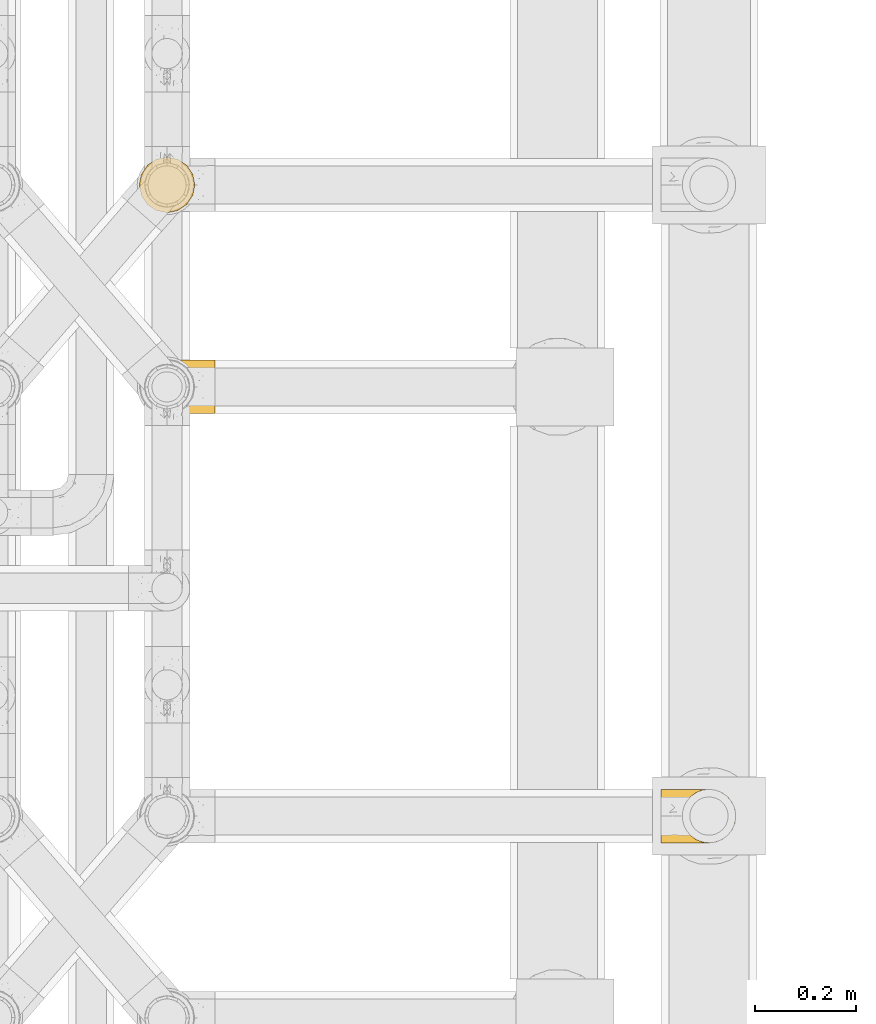
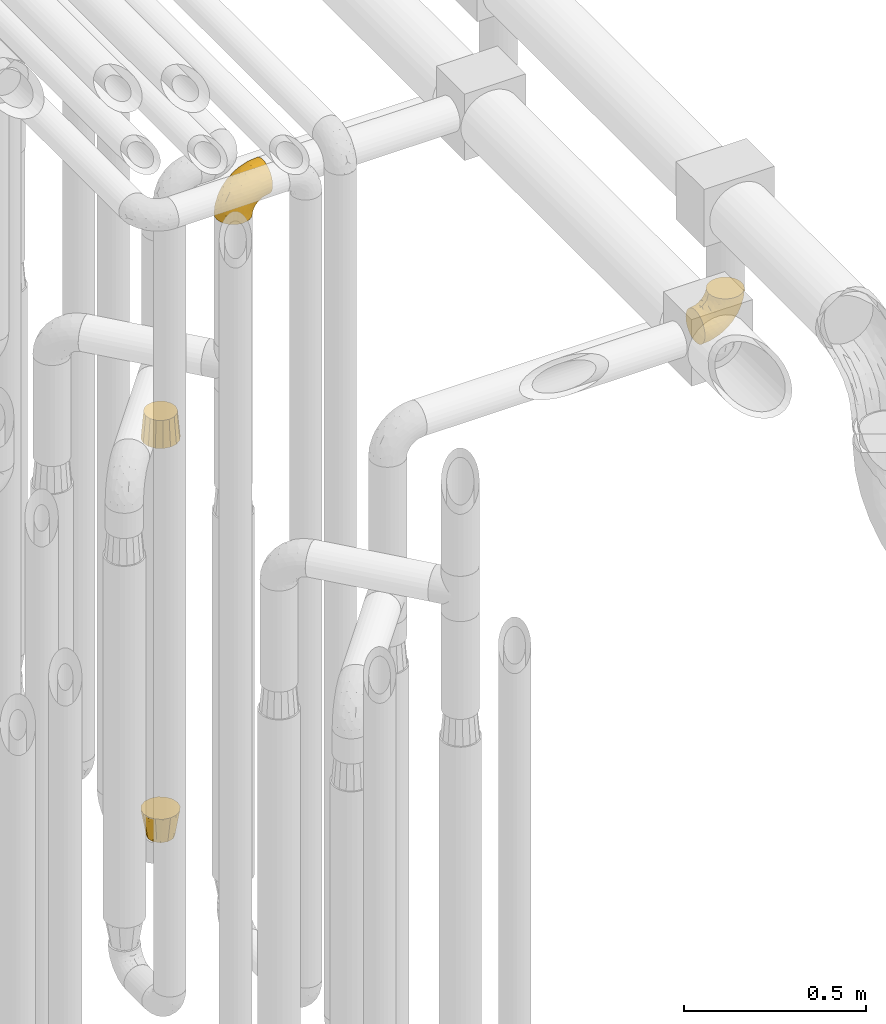
# One storey, part 220 of 827: 4 coverings.
"""IFC2X3 building model written with IfcOpenShell, lengths in millimetres."""

from ifc_helpers import new_model, entity, si_unit, converted_unit, derived_unit, direction, frame, origin, place, context, subcontext, project, spatial, faceted_brep, element, save


model = new_model("IFC2X3")

# Units and contexts
model_context = context("Model", 3, precision=0.01, world=origin(), true_north=direction((6.12303176911189e-17, 1.0)))
body_context = subcontext(model_context, "Body", "Model", "MODEL_VIEW")
ifc_project = project(units=[si_unit("LENGTHUNIT", "METRE", prefix="MILLI"), si_unit("AREAUNIT", "SQUARE_METRE"), si_unit("VOLUMEUNIT", "CUBIC_METRE"), converted_unit("PLANEANGLEUNIT", "DEGREE", entity("IfcRatioMeasure", 0.0174532925199433), si_unit("PLANEANGLEUNIT", "RADIAN"), dimensions=[0, 0, 0, 0, 0, 0, 0]), si_unit("MASSUNIT", "GRAM", prefix="KILO"), derived_unit("MASSDENSITYUNIT", [(si_unit("MASSUNIT", "GRAM", prefix="KILO"), 1), (si_unit("LENGTHUNIT", "METRE"), -3)]), derived_unit("MOMENTOFINERTIAUNIT", [(si_unit("LENGTHUNIT", "METRE"), 4)]), si_unit("TIMEUNIT", "SECOND"), si_unit("FREQUENCYUNIT", "HERTZ"), si_unit("THERMODYNAMICTEMPERATUREUNIT", "DEGREE_CELSIUS"), derived_unit("THERMALTRANSMITTANCEUNIT", [(si_unit("MASSUNIT", "GRAM", prefix="KILO"), 1), (si_unit("THERMODYNAMICTEMPERATUREUNIT", "KELVIN"), -1), (si_unit("TIMEUNIT", "SECOND"), -3)]), derived_unit("VOLUMETRICFLOWRATEUNIT", [(si_unit("LENGTHUNIT", "METRE"), 3), (si_unit("TIMEUNIT", "SECOND"), -1)]), derived_unit("MASSFLOWRATEUNIT", [(si_unit("MASSUNIT", "GRAM", prefix="KILO"), 1), (si_unit("TIMEUNIT", "SECOND"), -1)]), derived_unit("ROTATIONALFREQUENCYUNIT", [(si_unit("TIMEUNIT", "SECOND"), -1)]), si_unit("ELECTRICCURRENTUNIT", "AMPERE"), si_unit("ELECTRICVOLTAGEUNIT", "VOLT"), si_unit("POWERUNIT", "WATT"), si_unit("FORCEUNIT", "NEWTON", prefix="KILO"), si_unit("ILLUMINANCEUNIT", "LUX"), si_unit("LUMINOUSFLUXUNIT", "LUMEN"), si_unit("LUMINOUSINTENSITYUNIT", "CANDELA"), derived_unit("USERDEFINED", [(si_unit("MASSUNIT", "GRAM", prefix="KILO"), -1), (si_unit("LENGTHUNIT", "METRE"), -2), (si_unit("TIMEUNIT", "SECOND"), 3), (si_unit("LUMINOUSFLUXUNIT", "LUMEN"), 1)]), derived_unit("LINEARVELOCITYUNIT", [(si_unit("LENGTHUNIT", "METRE"), 1), (si_unit("TIMEUNIT", "SECOND"), -1)]), si_unit("PRESSUREUNIT", "PASCAL"), derived_unit("USERDEFINED", [(si_unit("LENGTHUNIT", "METRE"), -2), (si_unit("MASSUNIT", "GRAM", prefix="KILO"), 1), (si_unit("TIMEUNIT", "SECOND"), -2)]), derived_unit("LINEARFORCEUNIT", [(si_unit("MASSUNIT", "GRAM", prefix="KILO"), 1), (si_unit("LENGTHUNIT", "METRE"), 1), (si_unit("TIMEUNIT", "SECOND"), -2), (si_unit("LENGTHUNIT", "METRE"), -1)]), derived_unit("PLANARFORCEUNIT", [(si_unit("MASSUNIT", "GRAM", prefix="KILO"), 1), (si_unit("LENGTHUNIT", "METRE"), 1), (si_unit("TIMEUNIT", "SECOND"), -2), (si_unit("LENGTHUNIT", "METRE"), -2)])], contexts=[model_context])

# Site, building, storey
site_placement = place(None, origin())
site = spatial("IfcSite", under=ifc_project, at=site_placement, CompositionType="ELEMENT")
building_placement = place(site_placement, origin())
building = spatial("IfcBuilding", under=site, at=building_placement, CompositionType="ELEMENT")
storey_placement = place(building_placement, frame((0.0, 0.0, 28200.0)))
storey = spatial("IfcBuildingStorey", under=building, at=storey_placement, Name="08", CompositionType="ELEMENT", Elevation=28200.0)

# Coverings
covering_1_placement = place(storey_placement, frame((37951.7, 10425.56, 2545.35)))
element("IfcCovering", 1, at=covering_1_placement, inside=storey, Name=":ADSK_", ObjectType=":ADSK_", PredefinedType="INSULATION", context=body_context, shape_type="Brep", body=[
    faceted_brep([(1.6, 66.44, 2.92), (1.6, 54.65, 1.6), (1.6, 42.84, 2.93), (1.6, 31.62, 6.85), (1.6, 21.56, 13.18), (1.6, 13.16, 21.58), (1.6, 6.84, 31.64), (1.6, 2.92, 42.85), (1.6, 1.6, 54.65), (1.6, 2.93, 66.46), (1.6, 6.85, 77.67), (1.6, 13.18, 87.73), (1.6, 21.58, 96.13), (1.6, 31.64, 102.45), (1.6, 42.85, 106.37), (1.6, 54.65, 107.7), (1.6, 66.46, 106.36), (1.6, 77.67, 102.44), (1.6, 87.73, 96.11), (1.6, 96.13, 87.71), (1.6, 102.45, 77.65), (1.6, 106.37, 66.44), (1.6, 107.7, 54.65), (1.6, 106.36, 42.84), (1.6, 102.44, 31.62), (1.6, 96.11, 21.56), (1.6, 87.71, 13.16), (1.6, 77.65, 6.84), (45.35, 40.91, 149.65), (50.65, 28.12, 149.65), (59.08, 17.13, 149.65), (70.07, 8.7, 149.65), (82.86, 3.4, 149.65), (96.6, 1.6, 149.65), (110.33, 3.4, 149.65), (123.12, 8.7, 149.65), (134.11, 17.13, 149.65), (142.54, 28.12, 149.65), (147.84, 40.91, 149.65), (149.65, 54.65, 149.65), (147.84, 68.38, 149.65), (142.54, 81.17, 149.65), (134.11, 92.16, 149.65), (123.12, 100.59, 149.65), (110.33, 105.89, 149.65), (96.6, 107.7, 149.65), (82.86, 105.89, 149.65), (70.07, 100.59, 149.65), (59.08, 92.16, 149.65), (50.65, 81.17, 149.65), (45.35, 68.38, 149.65), (43.55, 54.65, 149.65), (137.19, 85.53, 123.27), (141.79, 73.42, 114.15), (128.89, 83.77, 92.97), (146.54, 64.22, 124.11), (144.6, 54.65, 111.33), (69.77, 96.72, 42.13), (94.41, 93.36, 56.83), (87.22, 84.47, 40.31), (117.2, 71.37, 61.55), (129.81, 54.65, 75.62), (106.28, 54.65, 44.96), (101.45, 103.47, 91.12), (115.81, 100.91, 109.83), (109.14, 99.1, 88.02), (107.65, 105.43, 119.19), (93.36, 106.79, 99.11), (59.44, 89.81, 27.97), (63.23, 79.59, 21.92), (35.59, 81.29, 12.94), (132.3, 74.01, 88.29), (138.41, 64.14, 95.35), (126.28, 94.75, 113.84), (39.91, 54.65, 6.64), (37.44, 70.74, 8.58), (90.35, 68.3, 33.39), (65.0, 66.05, 17.23), (85.4, 100.73, 61.99), (26.66, 106.78, 47.9), (29.88, 103.6, 37.72), (78.45, 107.7, 93.81), (85.2, 107.7, 107.05), (91.95, 107.7, 120.29), (77.98, 106.07, 73.26), (29.55, 90.59, 18.58), (41.42, 97.43, 29.72), (111.13, 84.51, 64.31), (114.67, 93.3, 82.84), (57.43, 107.7, 72.79), (67.94, 107.7, 83.3), (14.64, 107.7, 56.71), (30.95, 107.7, 59.29), (52.13, 106.79, 57.88), (44.19, 107.7, 66.04), (60.12, 103.47, 49.8), (75.62, 54.65, 21.43), (94.27, 107.7, 134.97), (24.59, 76.99, 108.79), (34.69, 84.28, 110.84), (31.15, 91.11, 101.53), (75.18, 106.26, 111.84), (67.55, 102.6, 119.98), (79.36, 106.08, 123.54), (84.32, 106.56, 134.54), (40.81, 105.36, 80.57), (29.93, 106.74, 69.55), (70.24, 101.59, 134.56), (37.93, 54.65, 128.67), (40.15, 54.65, 136.98), (42.1, 67.71, 133.56), (55.38, 91.36, 131.66), (52.17, 94.33, 117.75), (44.32, 87.1, 118.23), (19.85, 65.84, 110.55), (14.26, 54.65, 111.09), (22.57, 54.65, 113.32), (34.17, 68.92, 120.2), (54.85, 100.82, 105.95), (44.63, 79.83, 127.69), (47.52, 77.13, 139.88), (59.1, 105.9, 92.14), (44.11, 101.53, 93.82), (53.21, 106.72, 82.28), (62.86, 97.75, 130.86), (20.58, 103.08, 78.78), (15.79, 106.39, 67.58), (27.67, 98.1, 90.58), (13.49, 95.02, 90.23), (18.04, 86.9, 99.39), (12.44, 74.42, 105.17), (30.25, 54.65, 120.99), (66.71, 105.28, 104.59), (42.52, 92.87, 108.24), (55.38, 17.93, 131.66), (20.57, 6.22, 78.8), (42.11, 41.58, 133.57), (57.43, 1.6, 72.79), (53.22, 2.57, 82.27), (40.81, 3.94, 80.59), (19.85, 43.46, 110.55), (24.58, 32.32, 108.79), (34.16, 40.38, 120.2), (42.5, 16.44, 108.25), (54.93, 8.47, 106.06), (52.13, 15.01, 117.78), (27.66, 11.21, 90.6), (44.12, 7.78, 93.87), (78.45, 1.6, 93.81), (85.2, 1.6, 107.05), (75.17, 3.04, 111.89), (94.27, 1.6, 134.97), (84.32, 2.73, 134.54), (30.95, 1.6, 59.29), (44.19, 1.6, 66.04), (29.98, 2.55, 69.56), (66.78, 3.98, 104.56), (67.55, 6.69, 119.98), (70.24, 7.7, 134.56), (79.36, 3.21, 123.54), (13.48, 14.28, 90.25), (18.03, 22.42, 99.4), (34.66, 25.02, 110.83), (31.14, 18.18, 101.52), (12.43, 34.89, 105.18), (14.64, 1.6, 56.71), (47.52, 32.17, 139.89), (44.28, 22.23, 118.22), (15.8, 2.91, 67.6), (62.86, 11.54, 130.86), (67.94, 1.6, 83.3), (59.12, 3.38, 92.12), (44.64, 29.46, 127.71), (91.95, 1.6, 120.29), (128.89, 25.52, 92.97), (137.19, 23.76, 123.27), (126.28, 14.54, 113.84), (115.81, 8.38, 109.83), (146.53, 45.07, 124.03), (141.79, 35.87, 114.15), (139.45, 45.14, 98.04), (93.36, 2.5, 99.11), (26.67, 2.51, 47.9), (29.87, 5.68, 37.74), (60.12, 5.82, 49.8), (94.41, 15.93, 56.83), (69.76, 12.54, 42.16), (87.19, 24.81, 40.3), (52.13, 2.5, 57.88), (77.98, 3.22, 73.26), (107.65, 3.86, 119.19), (131.74, 35.85, 86.61), (59.44, 19.47, 27.99), (29.54, 18.68, 18.59), (63.2, 29.68, 21.92), (27.9, 27.95, 11.28), (90.35, 40.99, 33.39), (117.2, 37.92, 61.55), (41.39, 11.85, 29.73), (109.14, 10.19, 88.01), (85.46, 8.55, 62.08), (37.43, 38.53, 8.58), (114.67, 15.99, 82.84), (111.12, 24.79, 64.3), (101.45, 5.82, 91.12), (65.16, 40.56, 18.05)], [[[0, 1, 2, 3, 4, 5, 6, 7, 8, 9, 10, 11, 12, 13, 14, 15, 16, 17, 18, 19, 20, 21, 22, 23, 24, 25, 26, 27]], [[28, 29, 30, 31, 32, 33, 34, 35, 36, 37, 38, 39, 40, 41, 42, 43, 44, 45, 46, 47, 48, 49, 50, 51]], [[52, 53, 54]], [[55, 39, 56]], [[57, 58, 59]], [[60, 61, 62]], [[63, 64, 65]], [[66, 63, 67]], [[68, 69, 70]], [[53, 71, 54]], [[41, 40, 53]], [[53, 72, 71]], [[73, 42, 52]], [[42, 41, 52]], [[74, 0, 75]], [[69, 76, 77]], [[43, 73, 64]], [[45, 44, 66]], [[57, 78, 58]], [[23, 79, 80]], [[67, 81, 82, 83]], [[67, 84, 81]], [[24, 23, 80]], [[25, 85, 26]], [[86, 85, 25]], [[42, 73, 43]], [[0, 27, 75]], [[25, 24, 86]], [[70, 26, 85]], [[0, 74, 1]], [[68, 85, 86]], [[66, 64, 63]], [[60, 59, 87]], [[54, 87, 88]], [[76, 60, 62]], [[84, 89, 90, 81]], [[79, 22, 91, 92]], [[77, 74, 75]], [[93, 92, 94, 89]], [[80, 86, 24]], [[40, 55, 53]], [[76, 59, 60]], [[93, 84, 95]], [[76, 62, 96]], [[55, 72, 53]], [[70, 27, 26]], [[75, 70, 69]], [[78, 84, 63]], [[93, 79, 92]], [[95, 86, 80]], [[77, 76, 96]], [[59, 69, 68]], [[57, 68, 86]], [[68, 57, 59]], [[59, 58, 87]], [[76, 69, 59]], [[88, 87, 58]], [[87, 54, 71]], [[86, 95, 57]], [[78, 57, 95]], [[84, 78, 95]], [[78, 63, 65]], [[58, 78, 65]], [[54, 88, 73]], [[84, 93, 89]], [[79, 95, 80]], [[79, 93, 95]], [[22, 79, 23]], [[66, 83, 97, 45]], [[84, 67, 63]], [[83, 66, 67]], [[64, 44, 43]], [[64, 66, 44]], [[65, 73, 88]], [[53, 52, 41]], [[73, 52, 54]], [[73, 65, 64]], [[65, 88, 58]], [[39, 55, 40]], [[72, 55, 56]], [[56, 61, 72]], [[60, 72, 61]], [[72, 60, 71]], [[87, 71, 60]], [[27, 70, 75]], [[68, 70, 85]], [[74, 77, 96]], [[69, 77, 75]], [[98, 99, 100]], [[46, 45, 97]], [[101, 102, 103]], [[103, 104, 83]], [[105, 94, 106]], [[107, 103, 102]], [[108, 109, 51, 110]], [[111, 112, 113]], [[114, 115, 116]], [[47, 104, 107]], [[110, 117, 108]], [[49, 48, 111]], [[102, 118, 112]], [[119, 120, 111]], [[50, 49, 120]], [[121, 122, 118]], [[105, 123, 89]], [[124, 48, 107]], [[20, 19, 125]], [[121, 81, 90]], [[117, 119, 99]], [[21, 20, 126]], [[22, 21, 91]], [[105, 125, 127]], [[110, 51, 50]], [[19, 128, 125]], [[16, 15, 115]], [[129, 98, 100]], [[126, 91, 21]], [[128, 129, 127]], [[122, 123, 105]], [[114, 117, 98]], [[17, 16, 130]], [[18, 128, 19]], [[129, 18, 17]], [[125, 106, 126]], [[115, 114, 16]], [[130, 129, 17]], [[114, 98, 130]], [[117, 116, 131, 108]], [[99, 119, 113]], [[122, 121, 123]], [[92, 126, 106]], [[105, 127, 122]], [[132, 121, 118]], [[114, 130, 16]], [[129, 130, 98]], [[50, 120, 110]], [[129, 128, 18]], [[125, 128, 127]], [[125, 126, 20]], [[91, 126, 92]], [[105, 89, 94]], [[105, 106, 125]], [[94, 92, 106]], [[100, 122, 127]], [[118, 122, 133]], [[112, 118, 133]], [[132, 118, 102]], [[132, 102, 101]], [[81, 121, 132]], [[82, 103, 83]], [[132, 101, 81]], [[104, 47, 46]], [[124, 107, 102]], [[48, 47, 107]], [[113, 112, 133]], [[112, 111, 124]], [[99, 113, 133]], [[111, 113, 119]], [[99, 133, 100]], [[117, 99, 98]], [[122, 100, 133]], [[127, 129, 100]], [[103, 82, 101]], [[81, 101, 82]], [[112, 124, 102]], [[48, 124, 111]], [[104, 103, 107]], [[46, 97, 104]], [[111, 120, 49]], [[83, 104, 97]], [[110, 120, 119]], [[117, 110, 119]], [[116, 117, 114]], [[89, 123, 90]], [[90, 123, 121]], [[30, 29, 134]], [[11, 10, 135]], [[51, 109, 108, 136]], [[137, 138, 139]], [[140, 141, 142]], [[143, 144, 145]], [[146, 139, 147]], [[148, 149, 150]], [[151, 32, 152]], [[153, 154, 155]], [[156, 150, 157]], [[158, 157, 159]], [[108, 142, 136]], [[31, 158, 152]], [[160, 161, 12]], [[162, 163, 143]], [[140, 142, 116]], [[142, 141, 162]], [[14, 164, 140]], [[14, 140, 115]], [[9, 8, 165]], [[160, 12, 11]], [[141, 164, 161]], [[13, 12, 161]], [[14, 115, 15]], [[28, 166, 29]], [[135, 139, 146]], [[141, 163, 162]], [[135, 146, 160]], [[143, 167, 162]], [[29, 166, 134]], [[116, 142, 108, 131]], [[165, 153, 168]], [[10, 9, 168]], [[168, 135, 10]], [[138, 147, 139]], [[158, 169, 157]], [[14, 13, 164]], [[116, 115, 140]], [[145, 167, 143]], [[135, 160, 11]], [[168, 153, 155]], [[138, 170, 171]], [[157, 144, 156]], [[147, 144, 143]], [[161, 164, 13]], [[140, 164, 141]], [[142, 172, 136]], [[136, 172, 166]], [[161, 160, 146]], [[165, 168, 9]], [[155, 139, 135]], [[139, 154, 137]], [[168, 155, 135]], [[139, 155, 154]], [[144, 147, 171]], [[163, 147, 143]], [[156, 144, 171]], [[157, 169, 145]], [[171, 148, 156]], [[173, 159, 149]], [[159, 157, 150]], [[152, 159, 173]], [[159, 152, 158]], [[31, 30, 158]], [[169, 30, 134]], [[157, 145, 144]], [[167, 134, 172]], [[134, 167, 145]], [[172, 142, 162]], [[162, 167, 172]], [[163, 141, 161]], [[161, 146, 163]], [[147, 163, 146]], [[148, 150, 156]], [[149, 159, 150]], [[30, 169, 158]], [[145, 169, 134]], [[151, 33, 32]], [[31, 152, 32]], [[152, 173, 151]], [[28, 51, 136]], [[134, 166, 172]], [[28, 136, 166]], [[147, 138, 171]], [[170, 138, 137]], [[170, 148, 171]], [[174, 175, 176]], [[35, 34, 177]], [[178, 179, 180]], [[181, 173, 149, 148]], [[182, 183, 184]], [[185, 186, 187]], [[188, 189, 137]], [[190, 33, 151, 173]], [[191, 179, 174]], [[34, 190, 177]], [[39, 38, 178]], [[192, 193, 194]], [[4, 3, 195]], [[175, 179, 37]], [[38, 37, 179]], [[35, 176, 36]], [[196, 62, 197]], [[181, 190, 173]], [[37, 36, 175]], [[183, 6, 198]], [[189, 148, 170, 137]], [[185, 199, 200]], [[3, 2, 201]], [[202, 185, 203]], [[8, 7, 182]], [[200, 184, 186]], [[183, 7, 6]], [[181, 189, 204]], [[200, 189, 184]], [[5, 198, 6]], [[187, 203, 185]], [[195, 3, 201]], [[205, 196, 194]], [[62, 61, 197]], [[186, 198, 192]], [[180, 179, 191]], [[2, 1, 74]], [[198, 193, 192]], [[193, 5, 4]], [[194, 193, 195]], [[2, 74, 201]], [[5, 193, 198]], [[205, 74, 96]], [[188, 137, 154, 153]], [[62, 196, 96]], [[56, 178, 180]], [[198, 184, 183]], [[184, 188, 182]], [[203, 197, 191]], [[205, 194, 201]], [[187, 192, 194]], [[192, 187, 186]], [[194, 196, 187]], [[197, 187, 196]], [[197, 203, 187]], [[202, 174, 176]], [[200, 186, 185]], [[184, 198, 186]], [[199, 185, 202]], [[189, 200, 204]], [[174, 202, 203]], [[176, 177, 199]], [[189, 181, 148]], [[190, 181, 204]], [[190, 204, 177]], [[190, 34, 33]], [[188, 153, 182]], [[189, 188, 184]], [[182, 153, 165, 8]], [[183, 182, 7]], [[199, 177, 204]], [[35, 177, 176]], [[176, 175, 36]], [[179, 175, 174]], [[200, 199, 204]], [[176, 199, 202]], [[203, 191, 174]], [[180, 197, 61]], [[197, 180, 191]], [[61, 56, 180]], [[39, 178, 56]], [[38, 179, 178]], [[194, 195, 201]], [[4, 195, 193]], [[74, 205, 201]], [[96, 196, 205]]]),
])
covering_2_placement = place(storey_placement, frame((36918.44, 11673.61, 1811.0)))
element("IfcCovering", 2, at=covering_2_placement, inside=storey, Name=":ADSK_", ObjectType=":ADSK_", PredefinedType="INSULATION", context=body_context, shape_type="Brep", body=[
    faceted_brep([(56.6, 104.1, 89.0), (47.51, 102.29, 89.0), (38.42, 100.48, 89.0), (30.71, 95.33, 89.0), (23.01, 90.18, 89.0), (17.86, 82.48, 89.0), (12.71, 74.77, 89.0), (10.9, 65.68, 89.0), (9.1, 56.6, 89.0), (10.9, 47.51, 89.0), (12.71, 38.42, 89.0), (17.86, 30.71, 89.0), (23.01, 23.01, 89.0), (30.71, 17.86, 89.0), (38.42, 12.71, 89.0), (47.51, 10.9, 89.0), (56.6, 9.1, 89.0), (65.68, 10.9, 89.0), (74.77, 12.71, 89.0), (82.48, 17.86, 89.0), (90.18, 23.01, 89.0), (95.33, 30.71, 89.0), (100.48, 38.42, 89.0), (102.29, 47.51, 89.0), (104.1, 56.6, 89.0), (102.29, 65.68, 89.0), (100.48, 74.77, 89.0), (95.33, 82.48, 89.0), (90.18, 90.18, 89.0), (82.48, 95.33, 89.0), (74.77, 100.48, 89.0), (65.68, 102.29, 89.0), (77.64, 5.78, 0.0), (69.69, 4.2, 0.0), (56.6, 1.6, 0.0), (43.51, 4.2, 0.0), (35.55, 5.78, 0.0), (26.63, 11.74, 0.0), (17.7, 17.7, 0.0), (11.74, 26.63, 0.0), (5.78, 35.55, 0.0), (4.2, 43.51, 0.0), (1.6, 56.6, 0.0), (4.2, 69.69, 0.0), (5.78, 77.64, 0.0), (11.74, 86.56, 0.0), (17.7, 95.49, 0.0), (26.63, 101.45, 0.0), (35.55, 107.41, 0.0), (43.51, 108.99, 0.0), (56.6, 111.6, 0.0), (69.69, 108.99, 0.0), (77.64, 107.41, 0.0), (86.56, 101.45, 0.0), (95.49, 95.49, 0.0), (101.45, 86.56, 0.0), (107.41, 77.64, 0.0), (108.99, 69.69, 0.0), (111.6, 56.6, 0.0), (108.99, 43.51, 0.0), (107.41, 35.55, 0.0), (101.45, 26.63, 0.0), (95.49, 17.7, 0.0), (86.56, 11.74, 0.0)], [[[0, 1, 2, 3, 4, 5, 6, 7, 8, 9, 10, 11, 12, 13, 14, 15, 16, 17, 18, 19, 20, 21, 22, 23, 24, 25, 26, 27, 28, 29, 30, 31]], [[32, 33, 34, 35, 36, 37, 38, 39, 40, 41, 42, 43, 44, 45, 46, 47, 48, 49, 50, 51, 52, 53, 54, 55, 56, 57, 58, 59, 60, 61, 62, 63]], [[6, 44, 43, 42, 8, 7]], [[5, 4, 46, 45, 44, 6]], [[1, 0, 50, 49, 48, 2]], [[4, 3, 2, 48, 47, 46]], [[14, 36, 35, 34, 16, 15]], [[13, 12, 38, 37, 36, 14]], [[9, 8, 42, 41, 40, 10]], [[12, 11, 10, 40, 39, 38]], [[22, 60, 59, 58, 24, 23]], [[21, 20, 62, 61, 60, 22]], [[17, 16, 34, 33, 32, 18]], [[20, 19, 18, 32, 63, 62]], [[30, 52, 51, 50, 0, 31]], [[29, 28, 54, 53, 52, 30]], [[25, 24, 58, 57, 56, 26]], [[28, 27, 26, 56, 55, 54]]]),
])
covering_3_placement = place(storey_placement, frame((36918.44, 11673.61, 476.0)))
element("IfcCovering", 3, at=covering_3_placement, inside=storey, Name=":ADSK_", ObjectType=":ADSK_", PredefinedType="INSULATION", context=body_context, shape_type="Brep", body=[
    faceted_brep([(17.7, 95.49, 89.0), (11.74, 86.56, 89.0), (5.78, 77.64, 89.0), (3.69, 67.12, 89.0), (1.6, 56.6, 89.0), (3.69, 46.07, 89.0), (5.78, 35.55, 89.0), (11.74, 26.63, 89.0), (17.7, 17.7, 89.0), (26.63, 11.74, 89.0), (35.55, 5.78, 89.0), (46.07, 3.69, 89.0), (56.6, 1.6, 89.0), (67.12, 3.69, 89.0), (77.64, 5.78, 89.0), (86.56, 11.74, 89.0), (95.49, 17.7, 89.0), (101.45, 26.63, 89.0), (107.41, 35.55, 89.0), (109.5, 46.07, 89.0), (111.6, 56.6, 89.0), (109.5, 67.12, 89.0), (107.41, 77.64, 89.0), (101.45, 86.56, 89.0), (95.49, 95.49, 89.0), (86.56, 101.45, 89.0), (77.64, 107.41, 89.0), (67.12, 109.5, 89.0), (56.6, 111.6, 89.0), (46.07, 109.5, 89.0), (35.55, 107.41, 89.0), (26.63, 101.45, 89.0), (91.24, 76.6, 0.0), (93.92, 66.6, 0.0), (96.6, 56.6, 0.0), (93.92, 46.6, 0.0), (91.24, 36.6, 0.0), (83.92, 29.27, 0.0), (76.6, 21.95, 0.0), (66.6, 19.27, 0.0), (56.6, 16.6, 0.0), (46.6, 19.27, 0.0), (36.6, 21.95, 0.0), (29.27, 29.27, 0.0), (21.95, 36.6, 0.0), (19.27, 46.6, 0.0), (16.6, 56.6, 0.0), (19.27, 66.6, 0.0), (21.95, 76.6, 0.0), (29.27, 83.92, 0.0), (36.6, 91.24, 0.0), (46.6, 93.92, 0.0), (56.6, 96.6, 0.0), (66.6, 93.92, 0.0), (76.6, 91.24, 0.0), (83.92, 83.92, 0.0)], [[[0, 1, 2, 3, 4, 5, 6, 7, 8, 9, 10, 11, 12, 13, 14, 15, 16, 17, 18, 19, 20, 21, 22, 23, 24, 25, 26, 27, 28, 29, 30, 31]], [[32, 33, 34, 35, 36, 37, 38, 39, 40, 41, 42, 43, 44, 45, 46, 47, 48, 49, 50, 51, 52, 53, 54, 55]], [[21, 20, 34]], [[54, 25, 55]], [[55, 23, 32]], [[34, 33, 21]], [[24, 55, 25]], [[54, 26, 25]], [[23, 55, 24]], [[52, 27, 53]], [[23, 22, 32]], [[33, 32, 22]], [[27, 52, 28]], [[26, 54, 53]], [[27, 26, 53]], [[33, 22, 21]], [[29, 28, 52]], [[48, 1, 49]], [[49, 31, 50]], [[52, 51, 29]], [[0, 49, 1]], [[48, 2, 1]], [[31, 49, 0]], [[46, 3, 47]], [[31, 30, 50]], [[51, 50, 30]], [[3, 46, 4]], [[2, 48, 47]], [[3, 2, 47]], [[51, 30, 29]], [[5, 4, 46]], [[42, 9, 43]], [[43, 7, 44]], [[46, 45, 5]], [[8, 43, 9]], [[42, 10, 9]], [[7, 43, 8]], [[40, 11, 41]], [[7, 6, 44]], [[45, 44, 6]], [[11, 40, 12]], [[10, 42, 41]], [[11, 10, 41]], [[45, 6, 5]], [[13, 12, 40]], [[36, 17, 37]], [[37, 15, 38]], [[40, 39, 13]], [[16, 37, 17]], [[36, 18, 17]], [[15, 37, 16]], [[34, 19, 35]], [[15, 14, 38]], [[39, 38, 14]], [[19, 34, 20]], [[18, 36, 35]], [[19, 18, 35]], [[39, 14, 13]]]),
])
covering_4_placement = place(storey_placement, frame((36920.39, 11275.56, 2803.31)))
element("IfcCovering", 4, at=covering_4_placement, inside=storey, Name=":ADSK_", ObjectType=":ADSK_", PredefinedType="INSULATION", context=body_context, shape_type="Brep", body=[
    faceted_brep([(149.64, 96.11, 129.68), (149.64, 87.71, 138.08), (149.64, 77.65, 144.4), (149.64, 66.44, 148.32), (149.64, 54.65, 149.65), (149.64, 42.84, 148.31), (149.64, 31.62, 144.39), (149.64, 21.56, 138.06), (149.64, 13.16, 129.66), (149.64, 6.84, 119.6), (149.64, 2.92, 108.39), (149.64, 1.6, 96.6), (149.65, 2.93, 84.79), (149.65, 6.85, 73.57), (149.65, 13.18, 63.51), (149.65, 21.58, 55.11), (149.65, 31.64, 48.79), (149.65, 42.85, 44.87), (149.65, 54.65, 43.55), (149.65, 66.46, 44.88), (149.65, 77.67, 48.8), (149.65, 87.73, 55.13), (149.65, 96.13, 63.53), (149.65, 102.45, 73.59), (149.65, 106.37, 84.8), (149.64, 107.7, 96.6), (149.64, 106.36, 108.41), (149.64, 102.44, 119.62), (105.89, 40.91, 1.6), (100.59, 28.12, 1.6), (92.16, 17.13, 1.6), (81.17, 8.7, 1.6), (68.38, 3.4, 1.6), (54.65, 1.6, 1.6), (40.91, 3.4, 1.6), (28.12, 8.7, 1.6), (17.13, 17.13, 1.6), (8.7, 28.12, 1.6), (3.4, 40.91, 1.6), (1.6, 54.65, 1.6), (3.4, 68.38, 1.6), (8.7, 81.17, 1.6), (17.13, 92.16, 1.6), (28.12, 100.59, 1.6), (40.91, 105.89, 1.6), (54.65, 107.7, 1.6), (68.38, 105.89, 1.6), (81.17, 100.59, 1.6), (92.16, 92.16, 1.6), (100.59, 81.17, 1.6), (105.89, 68.38, 1.6), (107.7, 54.65, 1.6), (14.05, 85.53, 27.97), (9.45, 73.42, 37.09), (22.36, 83.77, 58.27), (4.7, 64.22, 27.13), (6.64, 54.65, 39.91), (81.47, 96.72, 109.11), (56.83, 93.36, 94.41), (64.02, 84.47, 110.94), (34.04, 71.37, 89.69), (21.43, 54.65, 75.62), (44.96, 54.65, 106.28), (49.8, 103.47, 60.12), (35.43, 100.91, 41.41), (42.1, 99.1, 63.22), (43.59, 105.43, 32.05), (57.88, 106.79, 52.13), (91.8, 89.81, 123.27), (88.01, 79.59, 129.32), (115.65, 81.29, 138.3), (18.94, 74.01, 62.95), (12.83, 64.14, 55.89), (24.96, 94.75, 37.4), (111.33, 54.65, 144.6), (113.8, 70.74, 142.66), (60.89, 68.3, 117.85), (86.24, 66.05, 134.01), (65.84, 100.73, 89.25), (124.58, 106.78, 103.34), (121.36, 103.6, 113.52), (72.79, 107.7, 57.43), (66.04, 107.7, 44.19), (59.29, 107.7, 30.95), (73.26, 106.07, 77.98), (121.69, 90.59, 132.66), (109.82, 97.43, 121.52), (40.11, 84.51, 86.93), (36.57, 93.3, 68.4), (93.81, 107.7, 78.45), (83.3, 107.7, 67.94), (136.6, 107.7, 94.53), (120.29, 107.7, 91.95), (99.11, 106.79, 93.36), (107.05, 107.7, 85.2), (91.12, 103.47, 101.45), (75.62, 54.65, 129.81), (56.97, 107.7, 16.27), (126.65, 76.99, 42.46), (116.55, 84.28, 40.4), (120.09, 91.11, 49.71), (76.06, 106.26, 39.4), (83.7, 102.6, 31.26), (71.88, 106.08, 27.7), (66.92, 106.56, 16.7), (110.43, 105.36, 70.67), (121.31, 106.74, 81.69), (81.0, 101.59, 16.68), (113.32, 54.65, 22.57), (111.09, 54.65, 14.26), (109.14, 67.71, 17.68), (95.86, 91.36, 19.58), (99.07, 94.33, 33.49), (106.92, 87.1, 33.01), (131.39, 65.84, 40.69), (136.98, 54.65, 40.15), (128.67, 54.65, 37.92), (117.07, 68.92, 31.04), (96.39, 100.82, 45.29), (106.61, 79.83, 23.55), (103.72, 77.13, 11.36), (92.14, 105.9, 59.1), (107.13, 101.53, 57.42), (98.03, 106.72, 68.96), (88.38, 97.75, 20.38), (130.66, 103.08, 72.46), (135.45, 106.39, 83.66), (123.57, 98.1, 60.66), (137.75, 95.02, 61.01), (133.2, 86.9, 51.85), (138.8, 74.42, 46.07), (120.99, 54.65, 30.25), (84.53, 105.28, 46.65), (108.72, 92.87, 43.0), (95.86, 17.93, 19.58), (130.67, 6.22, 72.44), (109.13, 41.58, 17.67), (93.81, 1.6, 78.45), (98.02, 2.57, 68.97), (110.43, 3.94, 70.65), (131.4, 43.46, 40.69), (126.66, 32.32, 42.45), (117.08, 40.38, 31.04), (108.74, 16.44, 42.99), (96.31, 8.47, 45.18), (99.11, 15.01, 33.46), (123.58, 11.21, 60.64), (107.12, 7.78, 57.37), (72.79, 1.6, 57.43), (66.04, 1.6, 44.19), (76.07, 3.04, 39.35), (56.97, 1.6, 16.27), (66.92, 2.73, 16.7), (120.29, 1.6, 91.95), (107.05, 1.6, 85.2), (121.26, 2.55, 81.68), (84.46, 3.98, 46.68), (83.7, 6.69, 31.26), (81.0, 7.7, 16.68), (71.88, 3.21, 27.7), (137.76, 14.28, 60.99), (133.21, 22.42, 51.84), (116.58, 25.02, 40.41), (120.1, 18.18, 49.72), (138.81, 34.89, 46.06), (136.6, 1.6, 94.53), (103.72, 32.17, 11.35), (106.96, 22.23, 33.02), (135.44, 2.91, 83.65), (88.38, 11.54, 20.38), (83.3, 1.6, 67.94), (106.6, 29.46, 23.53), (92.12, 3.38, 59.12), (59.29, 1.6, 30.95), (22.36, 25.52, 58.27), (14.05, 23.76, 27.97), (24.96, 14.54, 37.4), (35.43, 8.38, 41.41), (4.71, 45.07, 27.21), (9.45, 35.87, 37.09), (11.79, 45.14, 53.2), (57.88, 2.5, 52.13), (124.57, 2.51, 103.34), (121.37, 5.68, 113.5), (91.12, 5.82, 101.45), (56.83, 15.93, 94.41), (81.48, 12.54, 109.08), (64.05, 24.81, 110.94), (99.11, 2.5, 93.36), (73.26, 3.22, 77.98), (43.59, 3.86, 32.05), (19.5, 35.85, 64.63), (91.8, 19.47, 123.25), (121.7, 18.68, 132.65), (88.04, 29.68, 129.32), (123.34, 27.95, 139.96), (60.89, 40.99, 117.85), (34.04, 37.92, 89.69), (109.85, 11.85, 121.51), (42.1, 10.19, 63.23), (65.78, 8.55, 89.17), (113.81, 38.53, 142.66), (36.57, 15.99, 68.4), (40.12, 24.79, 86.94), (49.8, 5.82, 60.12), (86.08, 40.56, 133.2)], [[[0, 1, 2, 3, 4, 5, 6, 7, 8, 9, 10, 11, 12, 13, 14, 15, 16, 17, 18, 19, 20, 21, 22, 23, 24, 25, 26, 27]], [[28, 29, 30, 31, 32, 33, 34, 35, 36, 37, 38, 39, 40, 41, 42, 43, 44, 45, 46, 47, 48, 49, 50, 51]], [[52, 53, 54]], [[55, 39, 56]], [[57, 58, 59]], [[60, 61, 62]], [[63, 64, 65]], [[66, 63, 67]], [[68, 69, 70]], [[53, 71, 54]], [[41, 40, 53]], [[53, 72, 71]], [[73, 42, 52]], [[42, 41, 52]], [[74, 3, 75]], [[69, 76, 77]], [[43, 73, 64]], [[45, 44, 66]], [[57, 78, 58]], [[26, 79, 80]], [[67, 81, 82, 83]], [[67, 84, 81]], [[27, 26, 80]], [[0, 85, 1]], [[86, 85, 0]], [[42, 73, 43]], [[3, 2, 75]], [[0, 27, 86]], [[70, 1, 85]], [[3, 74, 4]], [[68, 85, 86]], [[66, 64, 63]], [[60, 59, 87]], [[54, 87, 88]], [[76, 60, 62]], [[84, 89, 90, 81]], [[79, 25, 91, 92]], [[77, 74, 75]], [[93, 92, 94, 89]], [[80, 86, 27]], [[40, 55, 53]], [[76, 59, 60]], [[93, 84, 95]], [[76, 62, 96]], [[55, 72, 53]], [[70, 2, 1]], [[75, 70, 69]], [[78, 84, 63]], [[93, 79, 92]], [[95, 86, 80]], [[77, 76, 96]], [[59, 69, 68]], [[57, 68, 86]], [[68, 57, 59]], [[59, 58, 87]], [[76, 69, 59]], [[88, 87, 58]], [[87, 54, 71]], [[86, 95, 57]], [[78, 57, 95]], [[84, 78, 95]], [[78, 63, 65]], [[58, 78, 65]], [[54, 88, 73]], [[84, 93, 89]], [[79, 95, 80]], [[79, 93, 95]], [[25, 79, 26]], [[66, 83, 97, 45]], [[84, 67, 63]], [[83, 66, 67]], [[64, 44, 43]], [[64, 66, 44]], [[65, 73, 88]], [[53, 52, 41]], [[73, 52, 54]], [[73, 65, 64]], [[65, 88, 58]], [[39, 55, 40]], [[72, 55, 56]], [[56, 61, 72]], [[60, 72, 61]], [[72, 60, 71]], [[87, 71, 60]], [[2, 70, 75]], [[68, 70, 85]], [[74, 77, 96]], [[69, 77, 75]], [[98, 99, 100]], [[46, 45, 97]], [[101, 102, 103]], [[103, 104, 83]], [[105, 94, 106]], [[107, 103, 102]], [[108, 109, 51, 110]], [[111, 112, 113]], [[114, 115, 116]], [[47, 104, 107]], [[110, 117, 108]], [[49, 48, 111]], [[102, 118, 112]], [[119, 120, 111]], [[50, 49, 120]], [[121, 122, 118]], [[105, 123, 89]], [[124, 48, 107]], [[23, 22, 125]], [[121, 81, 90]], [[117, 119, 99]], [[24, 23, 126]], [[25, 24, 91]], [[105, 125, 127]], [[110, 51, 50]], [[22, 128, 125]], [[19, 18, 115]], [[129, 98, 100]], [[126, 91, 24]], [[128, 129, 127]], [[122, 123, 105]], [[114, 117, 98]], [[20, 19, 130]], [[21, 128, 22]], [[129, 21, 20]], [[125, 106, 126]], [[115, 114, 19]], [[130, 129, 20]], [[114, 98, 130]], [[117, 116, 131, 108]], [[99, 119, 113]], [[122, 121, 123]], [[92, 126, 106]], [[105, 127, 122]], [[132, 121, 118]], [[114, 130, 19]], [[129, 130, 98]], [[50, 120, 110]], [[129, 128, 21]], [[125, 128, 127]], [[125, 126, 23]], [[91, 126, 92]], [[105, 89, 94]], [[105, 106, 125]], [[94, 92, 106]], [[100, 122, 127]], [[118, 122, 133]], [[112, 118, 133]], [[132, 118, 102]], [[132, 102, 101]], [[81, 121, 132]], [[82, 103, 83]], [[132, 101, 81]], [[104, 47, 46]], [[124, 107, 102]], [[48, 47, 107]], [[113, 112, 133]], [[112, 111, 124]], [[99, 113, 133]], [[111, 113, 119]], [[99, 133, 100]], [[117, 99, 98]], [[122, 100, 133]], [[127, 129, 100]], [[103, 82, 101]], [[81, 101, 82]], [[112, 124, 102]], [[48, 124, 111]], [[104, 103, 107]], [[46, 97, 104]], [[111, 120, 49]], [[83, 104, 97]], [[110, 120, 119]], [[117, 110, 119]], [[116, 117, 114]], [[123, 90, 89]], [[90, 123, 121]], [[30, 29, 134]], [[14, 13, 135]], [[51, 109, 108, 136]], [[137, 138, 139]], [[140, 141, 142]], [[143, 144, 145]], [[146, 139, 147]], [[148, 149, 150]], [[151, 32, 152]], [[153, 154, 155]], [[156, 150, 157]], [[158, 157, 159]], [[108, 142, 136]], [[31, 158, 152]], [[160, 161, 15]], [[162, 163, 143]], [[140, 142, 116]], [[142, 141, 162]], [[17, 164, 140]], [[17, 140, 115]], [[12, 11, 165]], [[160, 15, 14]], [[141, 164, 161]], [[16, 15, 161]], [[17, 115, 18]], [[28, 166, 29]], [[135, 139, 146]], [[141, 163, 162]], [[135, 146, 160]], [[143, 167, 162]], [[29, 166, 134]], [[116, 142, 108, 131]], [[165, 153, 168]], [[13, 12, 168]], [[168, 135, 13]], [[138, 147, 139]], [[158, 169, 157]], [[17, 16, 164]], [[116, 115, 140]], [[145, 167, 143]], [[135, 160, 14]], [[168, 153, 155]], [[138, 137, 170]], [[157, 144, 156]], [[147, 144, 143]], [[161, 164, 16]], [[140, 164, 141]], [[142, 171, 136]], [[136, 171, 166]], [[161, 160, 146]], [[165, 168, 12]], [[155, 139, 135]], [[139, 154, 137]], [[168, 155, 135]], [[139, 155, 154]], [[144, 147, 172]], [[163, 147, 143]], [[156, 144, 172]], [[157, 169, 145]], [[172, 148, 156]], [[173, 159, 149]], [[159, 157, 150]], [[152, 159, 173]], [[159, 152, 158]], [[31, 30, 158]], [[169, 30, 134]], [[157, 145, 144]], [[167, 134, 171]], [[134, 167, 145]], [[171, 142, 162]], [[162, 167, 171]], [[163, 141, 161]], [[161, 146, 163]], [[147, 163, 146]], [[148, 150, 156]], [[149, 159, 150]], [[30, 169, 158]], [[145, 169, 134]], [[151, 33, 32]], [[31, 152, 32]], [[152, 173, 151]], [[28, 51, 136]], [[134, 166, 171]], [[28, 136, 166]], [[138, 170, 172]], [[147, 138, 172]], [[148, 172, 170]], [[174, 175, 176]], [[35, 34, 177]], [[178, 179, 180]], [[181, 173, 149, 148]], [[182, 183, 184]], [[185, 186, 187]], [[188, 189, 137]], [[190, 33, 151, 173]], [[191, 179, 174]], [[34, 190, 177]], [[39, 38, 178]], [[192, 193, 194]], [[7, 6, 195]], [[175, 179, 37]], [[38, 37, 179]], [[35, 176, 36]], [[196, 62, 197]], [[181, 190, 173]], [[37, 36, 175]], [[183, 9, 198]], [[189, 148, 170, 137]], [[185, 199, 200]], [[6, 5, 201]], [[202, 185, 203]], [[11, 10, 182]], [[200, 184, 186]], [[183, 10, 9]], [[181, 189, 204]], [[200, 189, 184]], [[8, 198, 9]], [[187, 203, 185]], [[195, 6, 201]], [[205, 196, 194]], [[62, 61, 197]], [[186, 198, 192]], [[180, 179, 191]], [[5, 4, 74]], [[198, 193, 192]], [[193, 8, 7]], [[194, 193, 195]], [[5, 74, 201]], [[8, 193, 198]], [[205, 74, 96]], [[188, 137, 154, 153]], [[62, 196, 96]], [[56, 178, 180]], [[198, 184, 183]], [[184, 188, 182]], [[203, 197, 191]], [[205, 194, 201]], [[187, 192, 194]], [[192, 187, 186]], [[194, 196, 187]], [[197, 187, 196]], [[197, 203, 187]], [[202, 174, 176]], [[200, 186, 185]], [[184, 198, 186]], [[199, 185, 202]], [[189, 200, 204]], [[174, 202, 203]], [[176, 177, 199]], [[189, 181, 148]], [[190, 181, 204]], [[190, 204, 177]], [[190, 34, 33]], [[188, 153, 182]], [[189, 188, 184]], [[182, 153, 165, 11]], [[183, 182, 10]], [[199, 177, 204]], [[35, 177, 176]], [[176, 175, 36]], [[179, 175, 174]], [[200, 199, 204]], [[176, 199, 202]], [[203, 191, 174]], [[180, 197, 61]], [[197, 180, 191]], [[61, 56, 180]], [[39, 178, 56]], [[38, 179, 178]], [[194, 195, 201]], [[7, 195, 193]], [[74, 205, 201]], [[96, 196, 205]]]),
])

save(model, "model.ifc")
